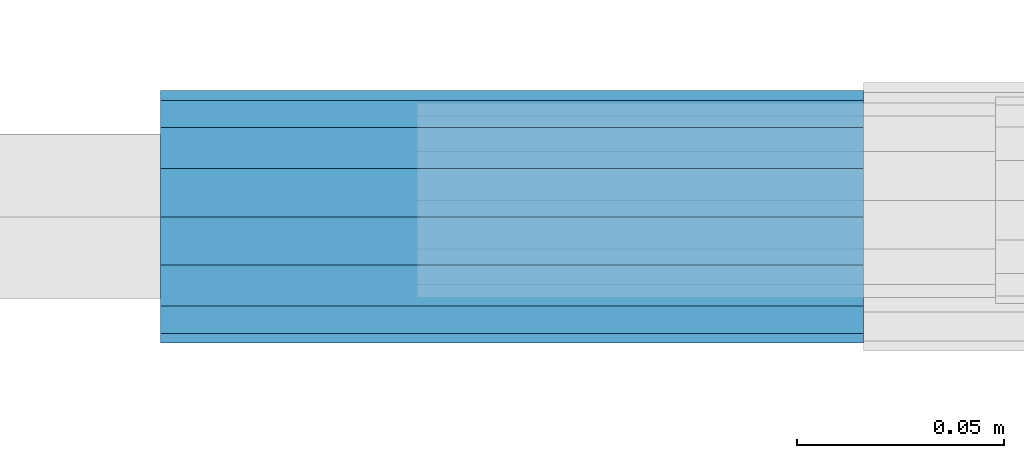
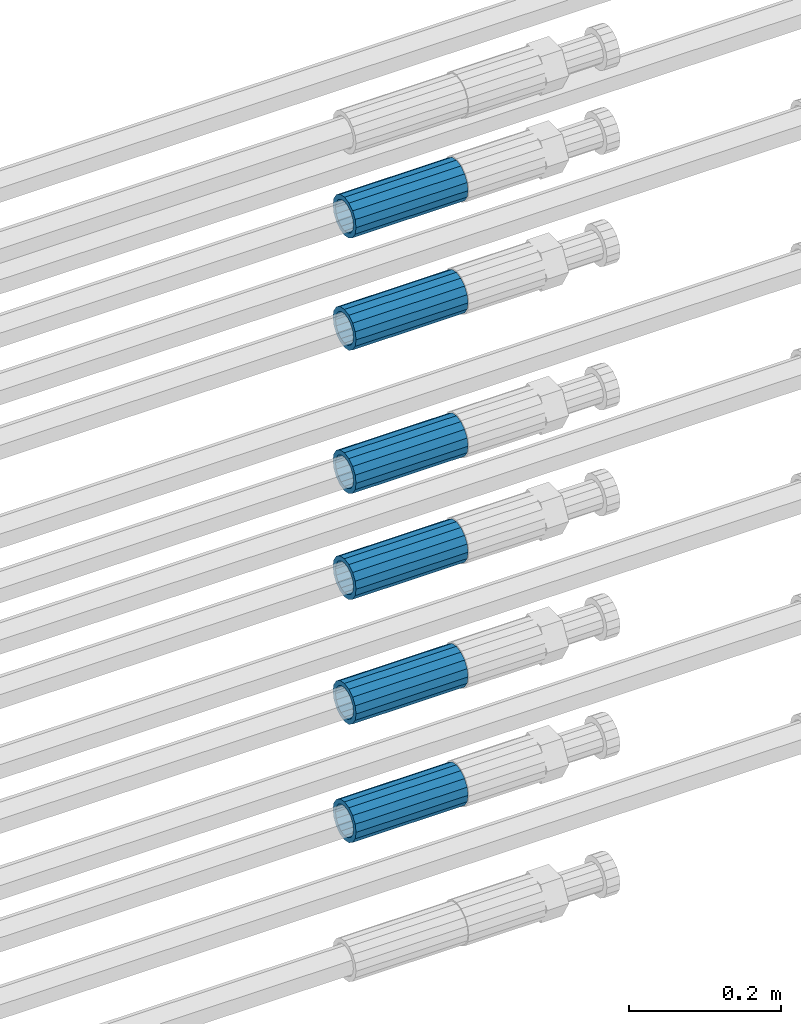
# One storey, part 108 of 119: 6 beams.
"""IFC2X3 building model written with IfcOpenShell, lengths in millimetres."""

from ifc_helpers import new_model, si_unit, frame, origin_with_axes, place, context, subcontext, project, spatial, faceted_brep, material, type_object, element, save


model = new_model("IFC2X3")

# Units and contexts
model_context = context("Model", 3, precision=1e-05, world=origin_with_axes())
body_context = subcontext(model_context, "Body", "Model", "MODEL_VIEW")
ifc_project = project(units=[si_unit("LENGTHUNIT", "METRE", prefix="MILLI"), si_unit("AREAUNIT", "SQUARE_METRE"), si_unit("VOLUMEUNIT", "CUBIC_METRE"), si_unit("MASSUNIT", "GRAM", prefix="KILO"), si_unit("TIMEUNIT", "SECOND"), si_unit("PLANEANGLEUNIT", "RADIAN"), si_unit("SOLIDANGLEUNIT", "STERADIAN"), si_unit("THERMODYNAMICTEMPERATUREUNIT", "DEGREE_CELSIUS"), si_unit("LUMINOUSINTENSITYUNIT", "LUMEN")], contexts=[model_context])

# Site, building, storey
site_placement = place(None, origin_with_axes())
site = spatial("IfcSite", under=ifc_project, at=site_placement, CompositionType="ELEMENT")
building_placement = place(site_placement, origin_with_axes())
building = spatial("IfcBuilding", under=site, at=building_placement, Name="Undefined", CompositionType="ELEMENT")
storey_placement = place(building_placement, origin_with_axes())
storey = spatial("IfcBuildingStorey", under=building, at=storey_placement, Name="Undefined", CompositionType="ELEMENT", Elevation=0.0)

# Beams
ifc_material = material(Name="STEEL/S275")
beam_type = type_object("IfcBeamType", PredefinedType="NOTDEFINED")
beam_1_placement = place(storey_placement, frame((2038589.02023304, 6206285.48994599, 22219.9894117228), z_axis=(0.0, 0.0, 1.0), x_axis=(1.0, 0.0, 0.0)))
element("IfcBeam", 1, at=beam_1_placement, inside=storey, type_object=beam_type, material=ifc_material, Name="AG40N", context=body_context, shape_type="Brep", body=[
    faceted_brep([(1.62981450557709e-09, -23.4999999990687, 0.0), (7.45058059692383e-09, -21.7111690142192, 8.99306066057534), (170.000002125278, -21.711168999318, 8.99306066022245), (170.000002127141, -23.4999999844003, -3.66071617463604e-10), (4.65661287307739e-09, -16.6170093587134, 16.6170093578889), (170.000002122484, -16.6170093440451, 16.6170093575288), (1.86264514923096e-09, -8.99306066217832, 21.7111690140277), (170.000002118759, -8.99306064750999, 21.7111690136603), (2.3283064365387e-10, 9.31322574615479e-10, 23.5), (170.000002114102, 1.28056854009628e-08, 23.4999999996485), (-6.51925802230835e-09, 8.99306065868586, 21.7111690140241), (170.00000211224, 8.99306067335419, 21.7111690136639), (-7.45058059692383e-09, 16.6170093561523, 16.6170093578853), (170.000002109446, 16.6170093708206, 16.6170093575324), (-9.31322574615479e-09, 21.711169013055, 8.99306066057534), (170.000002108514, 21.7111690277234, 8.99306066022245), (-1.16415321826935e-09, 23.5000000009313, 0.0), (170.000002108514, 23.5000000144355, -3.66071617463604e-10), (-8.38190317153931e-09, 21.7111690151505, -8.99306066059444), (170.000002110377, 21.7111690300517, -8.9930606609546), (-5.58793544769287e-09, 16.6170093598776, -16.6170093579008), (170.000002113171, 16.6170093745459, -16.6170093582609), (-9.31322574615479e-10, 8.99306066334248, -21.7111690140396), (170.000002115965, 8.99306067801081, -21.7111690143961), (2.3283064365387e-10, 9.31322574615479e-10, -23.5), (170.00000211969, 1.7927959561348e-08, -23.5000000003843), (5.58793544769287e-09, -8.99306065752171, -21.7111690140396), (170.000002123415, -8.99306064285338, -21.7111690143961), (8.38190317153931e-09, -16.6170093549881, -16.6170093579008), (170.000002125278, -16.6170093403198, -16.6170093582646), (9.31322574615479e-09, -21.7111690121237, -8.99306066059444), (170.000002127141, -21.7111689972226, -8.9930606609546), (1.11758708953857e-08, -30.4999999990687, -9.54969436861575e-12), (1.30385160446167e-08, -28.1783257392235, -11.6718446871514), (170.000002129003, -28.1783257243223, -11.6718446875116), (170.000002129935, -30.4999999841675, -3.66071617463604e-10), (1.02445483207703e-08, -21.5667568228673, -21.5667568262129), (170.000002128072, -21.566756808199, -21.5667568265694), (7.45058059692383e-09, -11.6718446831219, -28.1783257416196), (170.000002125278, -11.6718446684536, -28.1783257419834), (3.72529029846191e-09, 3.95812094211578e-09, -30.5000000000277), (170.00000211969, 1.83936208486557e-08, -30.5000000003879), (-9.31322574615479e-10, 11.6718446905725, -28.1783257416232), (170.000002115965, 11.6718447052408, -28.1783257419797), (-6.51925802230835e-09, 21.5667568286881, -21.5667568262093), (170.000002110377, 21.5667568433564, -21.5667568265694), (-9.31322574615479e-09, 28.178325742716, -11.6718446871478), (170.000002108514, 28.1783257573843, -11.6718446875079), (-1.21071934700012e-08, 30.5, -5.91171556152403e-12), (170.000002106652, 30.5000000144355, -3.62433638656512e-10), (-1.21071934700012e-08, 28.1783257401548, 11.6718446871359), (170.00000210572, 28.1783257548232, 11.6718446867794), (-1.02445483207703e-08, 21.5667568240315, 21.5667568261974), (170.000002107583, 21.566756838467, 21.5667568258409), (-7.45058059692383e-09, 11.671844684286, 28.1783257416041), (170.000002110377, 11.6718446989544, 28.178325741244), (-2.79396772384644e-09, -2.56113708019257e-09, 30.5000000000159), (170.000002114102, 1.18743628263474e-08, 30.4999999996558), (1.86264514923096e-09, -11.6718446896411, 28.1783257416114), (170.000002118759, -11.67184467474, 28.178325741244), (7.45058059692383e-09, -21.5667568275239, 21.5667568261974), (170.000002123415, -21.5667568126228, 21.5667568258373), (1.02445483207703e-08, -28.1783257415518, 11.6718446871359), (170.000002127141, -28.1783257271163, 11.6718446867794)], [[[0, 1, 2, 3]], [[1, 4, 5, 2]], [[4, 6, 7, 5]], [[6, 8, 9, 7]], [[8, 10, 11, 9]], [[10, 12, 13, 11]], [[12, 14, 15, 13]], [[14, 16, 17, 15]], [[16, 18, 19, 17]], [[18, 20, 21, 19]], [[20, 22, 23, 21]], [[22, 24, 25, 23]], [[24, 26, 27, 25]], [[26, 28, 29, 27]], [[28, 30, 31, 29]], [[30, 0, 3, 31]], [[32, 33, 34, 35]], [[33, 36, 37, 34]], [[36, 38, 39, 37]], [[38, 40, 41, 39]], [[40, 42, 43, 41]], [[42, 44, 45, 43]], [[44, 46, 47, 45]], [[46, 48, 49, 47]], [[48, 50, 51, 49]], [[50, 52, 53, 51]], [[52, 54, 55, 53]], [[54, 56, 57, 55]], [[56, 58, 59, 57]], [[58, 60, 61, 59]], [[60, 62, 63, 61]], [[62, 32, 35, 63]], [[37, 39, 41, 43, 45, 47, 49, 51, 53, 55, 57, 59, 61, 63, 35, 34], [5, 7, 9, 11, 13, 15, 17, 19, 21, 23, 25, 27, 29, 31, 3, 2]], [[62, 60, 58, 56, 54, 52, 50, 48, 46, 44, 42, 40, 38, 36, 33, 32], [30, 28, 26, 24, 22, 20, 18, 16, 14, 12, 10, 8, 6, 4, 1, 0]]]),
])
beam_2_placement = place(storey_placement, frame((2038589.02023304, 6206285.47994599, 22039.9894117228), z_axis=(0.0, 0.0, 1.0), x_axis=(1.0, 0.0, 0.0)))
element("IfcBeam", 2, at=beam_2_placement, inside=storey, type_object=beam_type, material=ifc_material, Name="AG40N", context=body_context, shape_type="Brep", body=[
    faceted_brep([(1.62981450557709e-09, -23.4999999990687, 0.0), (7.45058059692383e-09, -21.7111690142192, 8.99306066057534), (170.000002125278, -21.711168999318, 8.99306066022245), (170.000002127141, -23.4999999844003, -3.66071617463604e-10), (4.65661287307739e-09, -16.6170093587134, 16.6170093578889), (170.000002122484, -16.6170093440451, 16.6170093575288), (1.86264514923096e-09, -8.99306066217832, 21.7111690140277), (170.000002118759, -8.99306064750999, 21.7111690136603), (2.3283064365387e-10, 9.31322574615479e-10, 23.5), (170.000002114102, 1.28056854009628e-08, 23.4999999996485), (-6.51925802230835e-09, 8.99306065868586, 21.7111690140241), (170.00000211224, 8.99306067335419, 21.7111690136639), (-7.45058059692383e-09, 16.6170093561523, 16.6170093578853), (170.000002109446, 16.6170093708206, 16.6170093575324), (-9.31322574615479e-09, 21.711169013055, 8.99306066057534), (170.000002108514, 21.7111690277234, 8.99306066022245), (-1.16415321826935e-09, 23.5000000009313, 0.0), (170.000002108514, 23.5000000144355, -3.66071617463604e-10), (-8.38190317153931e-09, 21.7111690151505, -8.99306066059444), (170.000002110377, 21.7111690300517, -8.9930606609546), (-5.58793544769287e-09, 16.6170093598776, -16.6170093579008), (170.000002113171, 16.6170093745459, -16.6170093582609), (-9.31322574615479e-10, 8.99306066334248, -21.7111690140396), (170.000002115965, 8.99306067801081, -21.7111690143961), (2.3283064365387e-10, 9.31322574615479e-10, -23.5), (170.00000211969, 1.7927959561348e-08, -23.5000000003843), (5.58793544769287e-09, -8.99306065752171, -21.7111690140396), (170.000002123415, -8.99306064285338, -21.7111690143961), (8.38190317153931e-09, -16.6170093549881, -16.6170093579008), (170.000002125278, -16.6170093403198, -16.6170093582646), (9.31322574615479e-09, -21.7111690121237, -8.99306066059444), (170.000002127141, -21.7111689972226, -8.9930606609546), (1.11758708953857e-08, -30.4999999990687, -9.54969436861575e-12), (1.30385160446167e-08, -28.1783257392235, -11.6718446871514), (170.000002129003, -28.1783257243223, -11.6718446875116), (170.000002129935, -30.4999999841675, -3.66071617463604e-10), (1.02445483207703e-08, -21.5667568228673, -21.5667568262129), (170.000002128072, -21.566756808199, -21.5667568265694), (7.45058059692383e-09, -11.6718446831219, -28.1783257416196), (170.000002125278, -11.6718446684536, -28.1783257419834), (3.72529029846191e-09, 3.95812094211578e-09, -30.5000000000277), (170.00000211969, 1.83936208486557e-08, -30.5000000003879), (-9.31322574615479e-10, 11.6718446905725, -28.1783257416232), (170.000002115965, 11.6718447052408, -28.1783257419797), (-6.51925802230835e-09, 21.5667568286881, -21.5667568262093), (170.000002110377, 21.5667568433564, -21.5667568265694), (-9.31322574615479e-09, 28.178325742716, -11.6718446871478), (170.000002108514, 28.1783257573843, -11.6718446875079), (-1.21071934700012e-08, 30.5, -5.91171556152403e-12), (170.000002106652, 30.5000000144355, -3.62433638656512e-10), (-1.21071934700012e-08, 28.1783257401548, 11.6718446871359), (170.00000210572, 28.1783257548232, 11.6718446867794), (-1.02445483207703e-08, 21.5667568240315, 21.5667568261974), (170.000002107583, 21.566756838467, 21.5667568258409), (-7.45058059692383e-09, 11.671844684286, 28.1783257416041), (170.000002110377, 11.6718446989544, 28.178325741244), (-2.79396772384644e-09, -2.56113708019257e-09, 30.5000000000159), (170.000002114102, 1.18743628263474e-08, 30.4999999996558), (1.86264514923096e-09, -11.6718446896411, 28.1783257416114), (170.000002118759, -11.67184467474, 28.178325741244), (7.45058059692383e-09, -21.5667568275239, 21.5667568261974), (170.000002123415, -21.5667568126228, 21.5667568258373), (1.02445483207703e-08, -28.1783257415518, 11.6718446871359), (170.000002127141, -28.1783257271163, 11.6718446867794)], [[[0, 1, 2, 3]], [[1, 4, 5, 2]], [[4, 6, 7, 5]], [[6, 8, 9, 7]], [[8, 10, 11, 9]], [[10, 12, 13, 11]], [[12, 14, 15, 13]], [[14, 16, 17, 15]], [[16, 18, 19, 17]], [[18, 20, 21, 19]], [[20, 22, 23, 21]], [[22, 24, 25, 23]], [[24, 26, 27, 25]], [[26, 28, 29, 27]], [[28, 30, 31, 29]], [[30, 0, 3, 31]], [[32, 33, 34, 35]], [[33, 36, 37, 34]], [[36, 38, 39, 37]], [[38, 40, 41, 39]], [[40, 42, 43, 41]], [[42, 44, 45, 43]], [[44, 46, 47, 45]], [[46, 48, 49, 47]], [[48, 50, 51, 49]], [[50, 52, 53, 51]], [[52, 54, 55, 53]], [[54, 56, 57, 55]], [[56, 58, 59, 57]], [[58, 60, 61, 59]], [[60, 62, 63, 61]], [[62, 32, 35, 63]], [[37, 39, 41, 43, 45, 47, 49, 51, 53, 55, 57, 59, 61, 63, 35, 34], [5, 7, 9, 11, 13, 15, 17, 19, 21, 23, 25, 27, 29, 31, 3, 2]], [[62, 60, 58, 56, 54, 52, 50, 48, 46, 44, 42, 40, 38, 36, 33, 32], [30, 28, 26, 24, 22, 20, 18, 16, 14, 12, 10, 8, 6, 4, 1, 0]]]),
])
beam_3_placement = place(storey_placement, frame((2038589.02023304, 6206285.48994599, 21809.9894117228), z_axis=(0.0, 0.0, 1.0), x_axis=(1.0, 0.0, 0.0)))
element("IfcBeam", 3, at=beam_3_placement, inside=storey, type_object=beam_type, material=ifc_material, Name="AG40N", context=body_context, shape_type="Brep", body=[
    faceted_brep([(1.62981450557709e-09, -23.4999999990687, 0.0), (7.45058059692383e-09, -21.7111690142192, 8.99306066057534), (170.000002125278, -21.711168999318, 8.99306066022245), (170.000002127141, -23.4999999844003, -3.66071617463604e-10), (4.65661287307739e-09, -16.6170093587134, 16.6170093578889), (170.000002122484, -16.6170093440451, 16.6170093575288), (1.86264514923096e-09, -8.99306066217832, 21.7111690140277), (170.000002118759, -8.99306064750999, 21.7111690136603), (2.3283064365387e-10, 9.31322574615479e-10, 23.5), (170.000002114102, 1.28056854009628e-08, 23.4999999996485), (-6.51925802230835e-09, 8.99306065868586, 21.7111690140241), (170.00000211224, 8.99306067335419, 21.7111690136639), (-7.45058059692383e-09, 16.6170093561523, 16.6170093578853), (170.000002109446, 16.6170093708206, 16.6170093575324), (-9.31322574615479e-09, 21.711169013055, 8.99306066057534), (170.000002108514, 21.7111690277234, 8.99306066022245), (-1.16415321826935e-09, 23.5000000009313, 0.0), (170.000002108514, 23.5000000144355, -3.66071617463604e-10), (-8.38190317153931e-09, 21.7111690151505, -8.99306066059444), (170.000002110377, 21.7111690300517, -8.9930606609546), (-5.58793544769287e-09, 16.6170093598776, -16.6170093579008), (170.000002113171, 16.6170093745459, -16.6170093582609), (-9.31322574615479e-10, 8.99306066334248, -21.7111690140396), (170.000002115965, 8.99306067801081, -21.7111690143961), (2.3283064365387e-10, 9.31322574615479e-10, -23.5), (170.00000211969, 1.7927959561348e-08, -23.5000000003843), (5.58793544769287e-09, -8.99306065752171, -21.7111690140396), (170.000002123415, -8.99306064285338, -21.7111690143961), (8.38190317153931e-09, -16.6170093549881, -16.6170093579008), (170.000002125278, -16.6170093403198, -16.6170093582646), (9.31322574615479e-09, -21.7111690121237, -8.99306066059444), (170.000002127141, -21.7111689972226, -8.9930606609546), (1.11758708953857e-08, -30.4999999990687, -9.54969436861575e-12), (1.30385160446167e-08, -28.1783257392235, -11.6718446871514), (170.000002129003, -28.1783257243223, -11.6718446875116), (170.000002129935, -30.4999999841675, -3.66071617463604e-10), (1.02445483207703e-08, -21.5667568228673, -21.5667568262129), (170.000002128072, -21.566756808199, -21.5667568265694), (7.45058059692383e-09, -11.6718446831219, -28.1783257416196), (170.000002125278, -11.6718446684536, -28.1783257419834), (3.72529029846191e-09, 3.95812094211578e-09, -30.5000000000277), (170.00000211969, 1.83936208486557e-08, -30.5000000003879), (-9.31322574615479e-10, 11.6718446905725, -28.1783257416232), (170.000002115965, 11.6718447052408, -28.1783257419797), (-6.51925802230835e-09, 21.5667568286881, -21.5667568262093), (170.000002110377, 21.5667568433564, -21.5667568265694), (-9.31322574615479e-09, 28.178325742716, -11.6718446871478), (170.000002108514, 28.1783257573843, -11.6718446875079), (-1.21071934700012e-08, 30.5, -5.91171556152403e-12), (170.000002106652, 30.5000000144355, -3.62433638656512e-10), (-1.21071934700012e-08, 28.1783257401548, 11.6718446871359), (170.00000210572, 28.1783257548232, 11.6718446867794), (-1.02445483207703e-08, 21.5667568240315, 21.5667568261974), (170.000002107583, 21.566756838467, 21.5667568258409), (-7.45058059692383e-09, 11.671844684286, 28.1783257416041), (170.000002110377, 11.6718446989544, 28.178325741244), (-2.79396772384644e-09, -2.56113708019257e-09, 30.5000000000159), (170.000002114102, 1.18743628263474e-08, 30.4999999996558), (1.86264514923096e-09, -11.6718446896411, 28.1783257416114), (170.000002118759, -11.67184467474, 28.178325741244), (7.45058059692383e-09, -21.5667568275239, 21.5667568261974), (170.000002123415, -21.5667568126228, 21.5667568258373), (1.02445483207703e-08, -28.1783257415518, 11.6718446871359), (170.000002127141, -28.1783257271163, 11.6718446867794)], [[[0, 1, 2, 3]], [[1, 4, 5, 2]], [[4, 6, 7, 5]], [[6, 8, 9, 7]], [[8, 10, 11, 9]], [[10, 12, 13, 11]], [[12, 14, 15, 13]], [[14, 16, 17, 15]], [[16, 18, 19, 17]], [[18, 20, 21, 19]], [[20, 22, 23, 21]], [[22, 24, 25, 23]], [[24, 26, 27, 25]], [[26, 28, 29, 27]], [[28, 30, 31, 29]], [[30, 0, 3, 31]], [[32, 33, 34, 35]], [[33, 36, 37, 34]], [[36, 38, 39, 37]], [[38, 40, 41, 39]], [[40, 42, 43, 41]], [[42, 44, 45, 43]], [[44, 46, 47, 45]], [[46, 48, 49, 47]], [[48, 50, 51, 49]], [[50, 52, 53, 51]], [[52, 54, 55, 53]], [[54, 56, 57, 55]], [[56, 58, 59, 57]], [[58, 60, 61, 59]], [[60, 62, 63, 61]], [[62, 32, 35, 63]], [[37, 39, 41, 43, 45, 47, 49, 51, 53, 55, 57, 59, 61, 63, 35, 34], [5, 7, 9, 11, 13, 15, 17, 19, 21, 23, 25, 27, 29, 31, 3, 2]], [[62, 60, 58, 56, 54, 52, 50, 48, 46, 44, 42, 40, 38, 36, 33, 32], [30, 28, 26, 24, 22, 20, 18, 16, 14, 12, 10, 8, 6, 4, 1, 0]]]),
])
beam_4_placement = place(storey_placement, frame((2038589.02023304, 6206285.47994599, 21639.9894117228), z_axis=(0.0, 0.0, 1.0), x_axis=(1.0, 0.0, 0.0)))
element("IfcBeam", 4, at=beam_4_placement, inside=storey, type_object=beam_type, material=ifc_material, Name="AG40N", context=body_context, shape_type="Brep", body=[
    faceted_brep([(1.62981450557709e-09, -23.4999999990687, 0.0), (7.45058059692383e-09, -21.7111690142192, 8.99306066057534), (170.000002125278, -21.711168999318, 8.99306066022245), (170.000002127141, -23.4999999844003, -3.66071617463604e-10), (4.65661287307739e-09, -16.6170093587134, 16.6170093578889), (170.000002122484, -16.6170093440451, 16.6170093575288), (1.86264514923096e-09, -8.99306066217832, 21.7111690140277), (170.000002118759, -8.99306064750999, 21.7111690136603), (2.3283064365387e-10, 9.31322574615479e-10, 23.5), (170.000002114102, 1.28056854009628e-08, 23.4999999996485), (-6.51925802230835e-09, 8.99306065868586, 21.7111690140241), (170.00000211224, 8.99306067335419, 21.7111690136639), (-7.45058059692383e-09, 16.6170093561523, 16.6170093578853), (170.000002109446, 16.6170093708206, 16.6170093575324), (-9.31322574615479e-09, 21.711169013055, 8.99306066057534), (170.000002108514, 21.7111690277234, 8.99306066022245), (-1.16415321826935e-09, 23.5000000009313, 0.0), (170.000002108514, 23.5000000144355, -3.66071617463604e-10), (-8.38190317153931e-09, 21.7111690151505, -8.99306066059444), (170.000002110377, 21.7111690300517, -8.9930606609546), (-5.58793544769287e-09, 16.6170093598776, -16.6170093579008), (170.000002113171, 16.6170093745459, -16.6170093582609), (-9.31322574615479e-10, 8.99306066334248, -21.7111690140396), (170.000002115965, 8.99306067801081, -21.7111690143961), (2.3283064365387e-10, 9.31322574615479e-10, -23.5), (170.00000211969, 1.7927959561348e-08, -23.5000000003843), (5.58793544769287e-09, -8.99306065752171, -21.7111690140396), (170.000002123415, -8.99306064285338, -21.7111690143961), (8.38190317153931e-09, -16.6170093549881, -16.6170093579008), (170.000002125278, -16.6170093403198, -16.6170093582646), (9.31322574615479e-09, -21.7111690121237, -8.99306066059444), (170.000002127141, -21.7111689972226, -8.9930606609546), (1.11758708953857e-08, -30.4999999990687, -9.54969436861575e-12), (1.30385160446167e-08, -28.1783257392235, -11.6718446871514), (170.000002129003, -28.1783257243223, -11.6718446875116), (170.000002129935, -30.4999999841675, -3.66071617463604e-10), (1.02445483207703e-08, -21.5667568228673, -21.5667568262129), (170.000002128072, -21.566756808199, -21.5667568265694), (7.45058059692383e-09, -11.6718446831219, -28.1783257416196), (170.000002125278, -11.6718446684536, -28.1783257419834), (3.72529029846191e-09, 3.95812094211578e-09, -30.5000000000277), (170.00000211969, 1.83936208486557e-08, -30.5000000003879), (-9.31322574615479e-10, 11.6718446905725, -28.1783257416232), (170.000002115965, 11.6718447052408, -28.1783257419797), (-6.51925802230835e-09, 21.5667568286881, -21.5667568262093), (170.000002110377, 21.5667568433564, -21.5667568265694), (-9.31322574615479e-09, 28.178325742716, -11.6718446871478), (170.000002108514, 28.1783257573843, -11.6718446875079), (-1.21071934700012e-08, 30.5, -5.91171556152403e-12), (170.000002106652, 30.5000000144355, -3.62433638656512e-10), (-1.21071934700012e-08, 28.1783257401548, 11.6718446871359), (170.00000210572, 28.1783257548232, 11.6718446867794), (-1.02445483207703e-08, 21.5667568240315, 21.5667568261974), (170.000002107583, 21.566756838467, 21.5667568258409), (-7.45058059692383e-09, 11.671844684286, 28.1783257416041), (170.000002110377, 11.6718446989544, 28.178325741244), (-2.79396772384644e-09, -2.56113708019257e-09, 30.5000000000159), (170.000002114102, 1.18743628263474e-08, 30.4999999996558), (1.86264514923096e-09, -11.6718446896411, 28.1783257416114), (170.000002118759, -11.67184467474, 28.178325741244), (7.45058059692383e-09, -21.5667568275239, 21.5667568261974), (170.000002123415, -21.5667568126228, 21.5667568258373), (1.02445483207703e-08, -28.1783257415518, 11.6718446871359), (170.000002127141, -28.1783257271163, 11.6718446867794)], [[[0, 1, 2, 3]], [[1, 4, 5, 2]], [[4, 6, 7, 5]], [[6, 8, 9, 7]], [[8, 10, 11, 9]], [[10, 12, 13, 11]], [[12, 14, 15, 13]], [[14, 16, 17, 15]], [[16, 18, 19, 17]], [[18, 20, 21, 19]], [[20, 22, 23, 21]], [[22, 24, 25, 23]], [[24, 26, 27, 25]], [[26, 28, 29, 27]], [[28, 30, 31, 29]], [[30, 0, 3, 31]], [[32, 33, 34, 35]], [[33, 36, 37, 34]], [[36, 38, 39, 37]], [[38, 40, 41, 39]], [[40, 42, 43, 41]], [[42, 44, 45, 43]], [[44, 46, 47, 45]], [[46, 48, 49, 47]], [[48, 50, 51, 49]], [[50, 52, 53, 51]], [[52, 54, 55, 53]], [[54, 56, 57, 55]], [[56, 58, 59, 57]], [[58, 60, 61, 59]], [[60, 62, 63, 61]], [[62, 32, 35, 63]], [[37, 39, 41, 43, 45, 47, 49, 51, 53, 55, 57, 59, 61, 63, 35, 34], [5, 7, 9, 11, 13, 15, 17, 19, 21, 23, 25, 27, 29, 31, 3, 2]], [[62, 60, 58, 56, 54, 52, 50, 48, 46, 44, 42, 40, 38, 36, 33, 32], [30, 28, 26, 24, 22, 20, 18, 16, 14, 12, 10, 8, 6, 4, 1, 0]]]),
])
beam_5_placement = place(storey_placement, frame((2038589.02023304, 6206285.47994599, 21439.9894117228), z_axis=(0.0, 0.0, 1.0), x_axis=(1.0, 0.0, 0.0)))
element("IfcBeam", 5, at=beam_5_placement, inside=storey, type_object=beam_type, material=ifc_material, Name="AG40N", context=body_context, shape_type="Brep", body=[
    faceted_brep([(1.62981450557709e-09, -23.4999999990687, 0.0), (7.45058059692383e-09, -21.7111690142192, 8.99306066057534), (170.000002125278, -21.711168999318, 8.99306066022245), (170.000002127141, -23.4999999844003, -3.66071617463604e-10), (4.65661287307739e-09, -16.6170093587134, 16.6170093578889), (170.000002122484, -16.6170093440451, 16.6170093575288), (1.86264514923096e-09, -8.99306066217832, 21.7111690140277), (170.000002118759, -8.99306064750999, 21.7111690136603), (2.3283064365387e-10, 9.31322574615479e-10, 23.5), (170.000002114102, 1.28056854009628e-08, 23.4999999996485), (-6.51925802230835e-09, 8.99306065868586, 21.7111690140241), (170.00000211224, 8.99306067335419, 21.7111690136639), (-7.45058059692383e-09, 16.6170093561523, 16.6170093578853), (170.000002109446, 16.6170093708206, 16.6170093575324), (-9.31322574615479e-09, 21.711169013055, 8.99306066057534), (170.000002108514, 21.7111690277234, 8.99306066022245), (-1.16415321826935e-09, 23.5000000009313, 0.0), (170.000002108514, 23.5000000144355, -3.66071617463604e-10), (-8.38190317153931e-09, 21.7111690151505, -8.99306066059444), (170.000002110377, 21.7111690300517, -8.9930606609546), (-5.58793544769287e-09, 16.6170093598776, -16.6170093579008), (170.000002113171, 16.6170093745459, -16.6170093582609), (-9.31322574615479e-10, 8.99306066334248, -21.7111690140396), (170.000002115965, 8.99306067801081, -21.7111690143961), (2.3283064365387e-10, 9.31322574615479e-10, -23.5), (170.00000211969, 1.7927959561348e-08, -23.5000000003843), (5.58793544769287e-09, -8.99306065752171, -21.7111690140396), (170.000002123415, -8.99306064285338, -21.7111690143961), (8.38190317153931e-09, -16.6170093549881, -16.6170093579008), (170.000002125278, -16.6170093403198, -16.6170093582646), (9.31322574615479e-09, -21.7111690121237, -8.99306066059444), (170.000002127141, -21.7111689972226, -8.9930606609546), (1.11758708953857e-08, -30.4999999990687, -9.54969436861575e-12), (1.30385160446167e-08, -28.1783257392235, -11.6718446871514), (170.000002129003, -28.1783257243223, -11.6718446875116), (170.000002129935, -30.4999999841675, -3.66071617463604e-10), (1.02445483207703e-08, -21.5667568228673, -21.5667568262129), (170.000002128072, -21.566756808199, -21.5667568265694), (7.45058059692383e-09, -11.6718446831219, -28.1783257416196), (170.000002125278, -11.6718446684536, -28.1783257419834), (3.72529029846191e-09, 3.95812094211578e-09, -30.5000000000277), (170.00000211969, 1.83936208486557e-08, -30.5000000003879), (-9.31322574615479e-10, 11.6718446905725, -28.1783257416232), (170.000002115965, 11.6718447052408, -28.1783257419797), (-6.51925802230835e-09, 21.5667568286881, -21.5667568262093), (170.000002110377, 21.5667568433564, -21.5667568265694), (-9.31322574615479e-09, 28.178325742716, -11.6718446871478), (170.000002108514, 28.1783257573843, -11.6718446875079), (-1.21071934700012e-08, 30.5, -5.91171556152403e-12), (170.000002106652, 30.5000000144355, -3.62433638656512e-10), (-1.21071934700012e-08, 28.1783257401548, 11.6718446871359), (170.00000210572, 28.1783257548232, 11.6718446867794), (-1.02445483207703e-08, 21.5667568240315, 21.5667568261974), (170.000002107583, 21.566756838467, 21.5667568258409), (-7.45058059692383e-09, 11.671844684286, 28.1783257416041), (170.000002110377, 11.6718446989544, 28.178325741244), (-2.79396772384644e-09, -2.56113708019257e-09, 30.5000000000159), (170.000002114102, 1.18743628263474e-08, 30.4999999996558), (1.86264514923096e-09, -11.6718446896411, 28.1783257416114), (170.000002118759, -11.67184467474, 28.178325741244), (7.45058059692383e-09, -21.5667568275239, 21.5667568261974), (170.000002123415, -21.5667568126228, 21.5667568258373), (1.02445483207703e-08, -28.1783257415518, 11.6718446871359), (170.000002127141, -28.1783257271163, 11.6718446867794)], [[[0, 1, 2, 3]], [[1, 4, 5, 2]], [[4, 6, 7, 5]], [[6, 8, 9, 7]], [[8, 10, 11, 9]], [[10, 12, 13, 11]], [[12, 14, 15, 13]], [[14, 16, 17, 15]], [[16, 18, 19, 17]], [[18, 20, 21, 19]], [[20, 22, 23, 21]], [[22, 24, 25, 23]], [[24, 26, 27, 25]], [[26, 28, 29, 27]], [[28, 30, 31, 29]], [[30, 0, 3, 31]], [[32, 33, 34, 35]], [[33, 36, 37, 34]], [[36, 38, 39, 37]], [[38, 40, 41, 39]], [[40, 42, 43, 41]], [[42, 44, 45, 43]], [[44, 46, 47, 45]], [[46, 48, 49, 47]], [[48, 50, 51, 49]], [[50, 52, 53, 51]], [[52, 54, 55, 53]], [[54, 56, 57, 55]], [[56, 58, 59, 57]], [[58, 60, 61, 59]], [[60, 62, 63, 61]], [[62, 32, 35, 63]], [[37, 39, 41, 43, 45, 47, 49, 51, 53, 55, 57, 59, 61, 63, 35, 34], [5, 7, 9, 11, 13, 15, 17, 19, 21, 23, 25, 27, 29, 31, 3, 2]], [[62, 60, 58, 56, 54, 52, 50, 48, 46, 44, 42, 40, 38, 36, 33, 32], [30, 28, 26, 24, 22, 20, 18, 16, 14, 12, 10, 8, 6, 4, 1, 0]]]),
])
beam_6_placement = place(storey_placement, frame((2038589.02023304, 6206285.47994599, 21249.9894117228), z_axis=(0.0, 0.0, 1.0), x_axis=(1.0, 0.0, 0.0)))
element("IfcBeam", 6, at=beam_6_placement, inside=storey, type_object=beam_type, material=ifc_material, Name="AG40N", context=body_context, shape_type="Brep", body=[
    faceted_brep([(1.62981450557709e-09, -23.4999999990687, 0.0), (7.45058059692383e-09, -21.7111690142192, 8.99306066057534), (170.000002125278, -21.711168999318, 8.99306066022245), (170.000002127141, -23.4999999844003, -3.66071617463604e-10), (4.65661287307739e-09, -16.6170093587134, 16.6170093578889), (170.000002122484, -16.6170093440451, 16.6170093575288), (1.86264514923096e-09, -8.99306066217832, 21.7111690140277), (170.000002118759, -8.99306064750999, 21.7111690136603), (2.3283064365387e-10, 9.31322574615479e-10, 23.5), (170.000002114102, 1.28056854009628e-08, 23.4999999996485), (-6.51925802230835e-09, 8.99306065868586, 21.7111690140241), (170.00000211224, 8.99306067335419, 21.7111690136639), (-7.45058059692383e-09, 16.6170093561523, 16.6170093578853), (170.000002109446, 16.6170093708206, 16.6170093575324), (-9.31322574615479e-09, 21.711169013055, 8.99306066057534), (170.000002108514, 21.7111690277234, 8.99306066022245), (-1.16415321826935e-09, 23.5000000009313, 0.0), (170.000002108514, 23.5000000144355, -3.66071617463604e-10), (-8.38190317153931e-09, 21.7111690151505, -8.99306066059444), (170.000002110377, 21.7111690300517, -8.9930606609546), (-5.58793544769287e-09, 16.6170093598776, -16.6170093579008), (170.000002113171, 16.6170093745459, -16.6170093582609), (-9.31322574615479e-10, 8.99306066334248, -21.7111690140396), (170.000002115965, 8.99306067801081, -21.7111690143961), (2.3283064365387e-10, 9.31322574615479e-10, -23.5), (170.00000211969, 1.7927959561348e-08, -23.5000000003843), (5.58793544769287e-09, -8.99306065752171, -21.7111690140396), (170.000002123415, -8.99306064285338, -21.7111690143961), (8.38190317153931e-09, -16.6170093549881, -16.6170093579008), (170.000002125278, -16.6170093403198, -16.6170093582646), (9.31322574615479e-09, -21.7111690121237, -8.99306066059444), (170.000002127141, -21.7111689972226, -8.9930606609546), (1.11758708953857e-08, -30.4999999990687, -9.54969436861575e-12), (1.30385160446167e-08, -28.1783257392235, -11.6718446871514), (170.000002129003, -28.1783257243223, -11.6718446875116), (170.000002129935, -30.4999999841675, -3.66071617463604e-10), (1.02445483207703e-08, -21.5667568228673, -21.5667568262129), (170.000002128072, -21.566756808199, -21.5667568265694), (7.45058059692383e-09, -11.6718446831219, -28.1783257416196), (170.000002125278, -11.6718446684536, -28.1783257419834), (3.72529029846191e-09, 3.95812094211578e-09, -30.5000000000277), (170.00000211969, 1.83936208486557e-08, -30.5000000003879), (-9.31322574615479e-10, 11.6718446905725, -28.1783257416232), (170.000002115965, 11.6718447052408, -28.1783257419797), (-6.51925802230835e-09, 21.5667568286881, -21.5667568262093), (170.000002110377, 21.5667568433564, -21.5667568265694), (-9.31322574615479e-09, 28.178325742716, -11.6718446871478), (170.000002108514, 28.1783257573843, -11.6718446875079), (-1.21071934700012e-08, 30.5, -5.91171556152403e-12), (170.000002106652, 30.5000000144355, -3.62433638656512e-10), (-1.21071934700012e-08, 28.1783257401548, 11.6718446871359), (170.00000210572, 28.1783257548232, 11.6718446867794), (-1.02445483207703e-08, 21.5667568240315, 21.5667568261974), (170.000002107583, 21.566756838467, 21.5667568258409), (-7.45058059692383e-09, 11.671844684286, 28.1783257416041), (170.000002110377, 11.6718446989544, 28.178325741244), (-2.79396772384644e-09, -2.56113708019257e-09, 30.5000000000159), (170.000002114102, 1.18743628263474e-08, 30.4999999996558), (1.86264514923096e-09, -11.6718446896411, 28.1783257416114), (170.000002118759, -11.67184467474, 28.178325741244), (7.45058059692383e-09, -21.5667568275239, 21.5667568261974), (170.000002123415, -21.5667568126228, 21.5667568258373), (1.02445483207703e-08, -28.1783257415518, 11.6718446871359), (170.000002127141, -28.1783257271163, 11.6718446867794)], [[[0, 1, 2, 3]], [[1, 4, 5, 2]], [[4, 6, 7, 5]], [[6, 8, 9, 7]], [[8, 10, 11, 9]], [[10, 12, 13, 11]], [[12, 14, 15, 13]], [[14, 16, 17, 15]], [[16, 18, 19, 17]], [[18, 20, 21, 19]], [[20, 22, 23, 21]], [[22, 24, 25, 23]], [[24, 26, 27, 25]], [[26, 28, 29, 27]], [[28, 30, 31, 29]], [[30, 0, 3, 31]], [[32, 33, 34, 35]], [[33, 36, 37, 34]], [[36, 38, 39, 37]], [[38, 40, 41, 39]], [[40, 42, 43, 41]], [[42, 44, 45, 43]], [[44, 46, 47, 45]], [[46, 48, 49, 47]], [[48, 50, 51, 49]], [[50, 52, 53, 51]], [[52, 54, 55, 53]], [[54, 56, 57, 55]], [[56, 58, 59, 57]], [[58, 60, 61, 59]], [[60, 62, 63, 61]], [[62, 32, 35, 63]], [[37, 39, 41, 43, 45, 47, 49, 51, 53, 55, 57, 59, 61, 63, 35, 34], [5, 7, 9, 11, 13, 15, 17, 19, 21, 23, 25, 27, 29, 31, 3, 2]], [[62, 60, 58, 56, 54, 52, 50, 48, 46, 44, 42, 40, 38, 36, 33, 32], [30, 28, 26, 24, 22, 20, 18, 16, 14, 12, 10, 8, 6, 4, 1, 0]]]),
])

save(model, "model.ifc")
